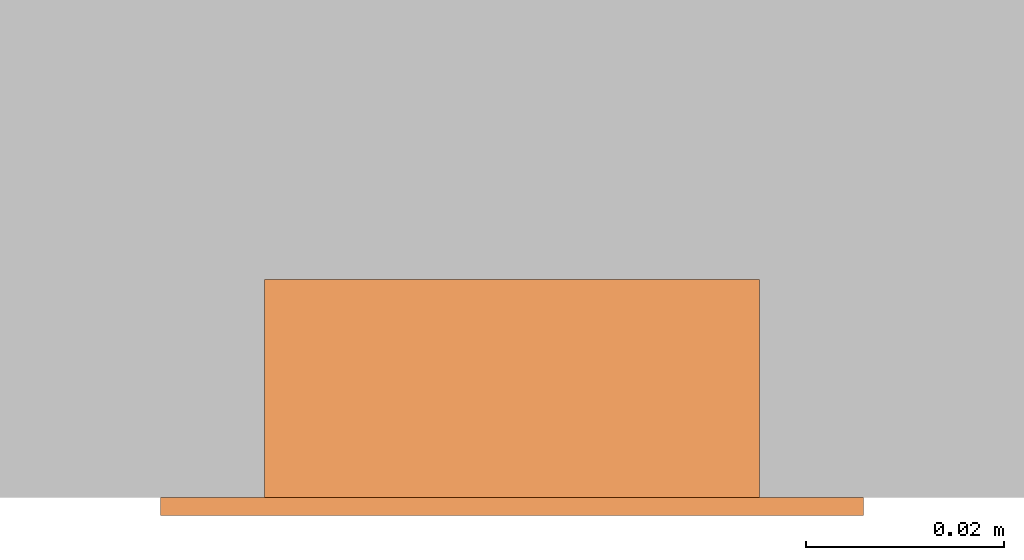
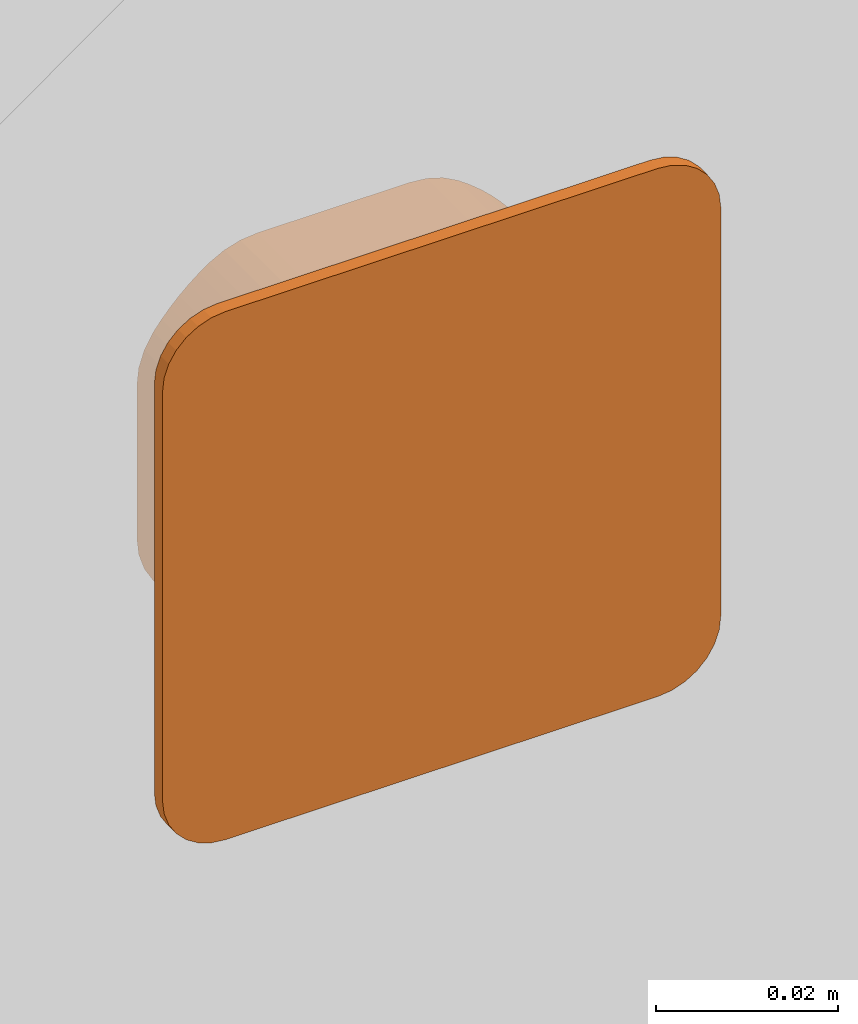
# One storey, part 2 of 2: 1 proxy.
"""IFC2X3 building model written with IfcOpenShell, lengths in metres."""

import ifcopenshell
import ifcopenshell.guid

model = None  # the IFC model being written
_history = None  # IfcOwnerHistory: only IFC2X3 demands one
_inside = {}  # id of a spatial element -> (the spatial element, [elements in it])
_under = {}  # id of a project, library or spatial element -> (it, [spatial elements below it])
_declared = {}  # id of a project -> (the project, [libraries it declares])
_typed = {}  # id of a type object -> (the type object, [elements of that type])
_made_of = {}  # id of a material, layer set ... -> (it, [elements and type objects made of it])


def new_model(schema):
    """Start an empty IFC model of exactly this schema.

    Asked for "IFC4X3", IfcOpenShell would pick the latest addendum, in which some entities
    have other attributes; the version numbers below select the first issue.
    IFC2X3 requires an IfcOwnerHistory on every rooted entity: one is made here for all.
    """
    global model, _history
    if schema == "IFC4X3":
        model = ifcopenshell.file(schema_version=(4, 3, 0, 0))
    else:
        model = ifcopenshell.file(schema=schema)
    _inside.clear()
    _under.clear()
    _declared.clear()
    _typed.clear()
    _made_of.clear()
    _history = None
    if model.schema == "IFC2X3":
        org = make("IfcOrganization", Name="unknown")
        user = make(
            "IfcPersonAndOrganization",
            ThePerson=make("IfcPerson", FamilyName="unknown"),
            TheOrganization=org,
        )
        app = make(
            "IfcApplication",
            ApplicationDeveloper=org,
            Version="unknown",
            ApplicationFullName="unknown",
            ApplicationIdentifier="unknown",
        )
        _history = make(
            "IfcOwnerHistory",
            OwningUser=user,
            OwningApplication=app,
            ChangeAction="ADDED",
            CreationDate=0,
        )
    return model


def make(cls, **values):
    """One entity of the class cls with the attributes given. An attribute that is None is left unset."""
    return model.create_entity(
        cls, **{name: value for name, value in values.items() if value is not None}
    )


def entity(cls, *values):
    """Any entity or typed value of the class cls, its attributes in the order of the schema. None: left unset."""
    e = model.create_entity(cls)
    for i, value in enumerate(values):
        if value is not None:
            e[i] = value
    return e


def rooted(cls, **values):
    """An entity with a GlobalId (a new one), such as an element, a storey or a relation."""
    return make(cls, GlobalId=ifcopenshell.guid.new(), OwnerHistory=_history, **values)


def si_unit(unit_type, name, prefix=None):
    """IfcSIUnit, for example si_unit("LENGTHUNIT", "METRE", prefix="MILLI")."""
    return make("IfcSIUnit", UnitType=unit_type, Prefix=prefix, Name=name)


def converted_unit(unit_type, name, factor, base, dimensions=None, offset=None):
    """IfcConversionBasedUnit, such as the inch: factor (a typed value) times the base unit."""
    return make(
        "IfcConversionBasedUnit"
        if offset is None
        else "IfcConversionBasedUnitWithOffset",
        ConversionOffset=offset,
        Dimensions=None
        if dimensions is None
        else entity("IfcDimensionalExponents", *dimensions),
        UnitType=unit_type,
        Name=name,
        ConversionFactor=make(
            "IfcMeasureWithUnit", ValueComponent=factor, UnitComponent=base
        ),
    )


def derived_unit(unit_type, elements):
    """IfcDerivedUnit: a product of units, each with its exponent."""
    return make(
        "IfcDerivedUnit",
        Elements=[
            make("IfcDerivedUnitElement", Unit=unit, Exponent=power)
            for unit, power in elements
        ],
        UnitType=unit_type,
    )


def assignment(units):
    """IfcUnitAssignment: the units of a project."""
    return None if units is None else make("IfcUnitAssignment", Units=units)


def point(xyz):
    """IfcCartesianPoint."""
    return None if xyz is None else make("IfcCartesianPoint", Coordinates=xyz)


def direction(xyz):
    """IfcDirection."""
    return None if xyz is None else make("IfcDirection", DirectionRatios=xyz)


def frame(location, z_axis=None, x_axis=None):
    """IfcAxis2Placement3D, a coordinate frame: its origin and axes. An axis left out is left unset."""
    return make(
        "IfcAxis2Placement3D",
        Location=point(location),
        Axis=direction(z_axis),
        RefDirection=direction(x_axis),
    )


def frame_2d(location, x_axis=None):
    """IfcAxis2Placement2D, a coordinate frame in the plane: its origin and x axis."""
    return make(
        "IfcAxis2Placement2D", Location=point(location), RefDirection=direction(x_axis)
    )


def origin():
    """The frame at (0, 0, 0) with its axes left unset."""
    return frame((0.0, 0.0, 0.0))


def place(relative_to, where):
    """IfcLocalPlacement: puts the frame where relative to a parent placement (None: the world)."""
    return make(
        "IfcLocalPlacement", PlacementRelTo=relative_to, RelativePlacement=where
    )


def context(
    kind, dimensions, precision=None, world=None, true_north=None, identifier=None
):
    """IfcGeometricRepresentationContext, for example the 3D "Model" context."""
    return make(
        "IfcGeometricRepresentationContext",
        ContextIdentifier=identifier,
        ContextType=kind,
        CoordinateSpaceDimension=dimensions,
        Precision=precision,
        WorldCoordinateSystem=world,
        TrueNorth=true_north,
    )


def subcontext(parent, identifier, kind, view, scale=None):
    """IfcGeometricRepresentationSubContext, for example "Body" below "Model"."""
    return make(
        "IfcGeometricRepresentationSubContext",
        ContextIdentifier=identifier,
        ContextType=kind,
        ParentContext=parent,
        TargetScale=scale,
        TargetView=view,
    )


def project(units=None, contexts=None):
    """IfcProject with its units and contexts."""
    return rooted(
        "IfcProject",
        Name="project",
        RepresentationContexts=contexts,
        UnitsInContext=assignment(units),
    )


def spatial(cls, under=None, at=None, **own):
    """A site, building, storey or space (cls), placed at a placement, below another one or the project."""
    s = rooted(cls, ObjectPlacement=at, **own)
    if under is not None:
        _under.setdefault(under.id(), (under, []))[1].append(s)
    return s


def polyline(points):
    """IfcPolyline through the points."""
    return make("IfcPolyline", Points=[point(p) for p in points])


def circle_curve(where, radius):
    """IfcCircle in the frame where."""
    return make("IfcCircle", Position=where, Radius=radius)


def parameter(value):
    """IfcParameterValue: where a trimmed curve begins or ends, as a parameter of its basis curve."""
    return model.create_entity("IfcParameterValue", value)


def trimmed(basis, trim1, trim2, sense, master):
    """IfcTrimmedCurve: the piece of a basis curve between two trims."""
    return make(
        "IfcTrimmedCurve",
        BasisCurve=basis,
        Trim1=trim1,
        Trim2=trim2,
        SenseAgreement=sense,
        MasterRepresentation=master,
    )


def segment(curve, same_sense, transition):
    """IfcCompositeCurveSegment."""
    return make(
        "IfcCompositeCurveSegment",
        Transition=transition,
        SameSense=same_sense,
        ParentCurve=curve,
    )


def composite_curve(segments, self_intersect=None):
    """IfcCompositeCurve: segments joined end to end."""
    return make("IfcCompositeCurve", Segments=segments, SelfIntersect=self_intersect)


def outline(outer, holes=None, kind="AREA"):
    """IfcArbitraryClosedProfileDef: a profile drawn as a closed curve; with holes, ...WithVoids."""
    if holes is None:
        return make("IfcArbitraryClosedProfileDef", ProfileType=kind, OuterCurve=outer)
    return make(
        "IfcArbitraryProfileDefWithVoids",
        ProfileType=kind,
        OuterCurve=outer,
        InnerCurves=holes,
    )


def extrude(swept, where, along, depth):
    """IfcExtrudedAreaSolid: the profile swept, set in the frame where, extruded along a direction by depth."""
    return make(
        "IfcExtrudedAreaSolid",
        SweptArea=swept,
        Position=where,
        ExtrudedDirection=direction(along),
        Depth=depth,
    )


def shape(context_of_items, identifier, shape_type, items):
    """IfcShapeRepresentation: the items that make up one representation, for example the "Body"."""
    return make(
        "IfcShapeRepresentation",
        ContextOfItems=context_of_items,
        RepresentationIdentifier=identifier,
        RepresentationType=shape_type,
        Items=items,
    )


def source(mapping_origin, context_of_items, identifier, shape_type, items):
    """IfcRepresentationMap: a shape defined once, which mapped items show again and again."""
    return make(
        "IfcRepresentationMap",
        MappingOrigin=mapping_origin,
        MappedRepresentation=shape(context_of_items, identifier, shape_type, items),
    )


def transform(
    local_origin,
    x_axis=None,
    y_axis=None,
    z_axis=None,
    scale=None,
    scale2=None,
    scale3=None,
    uniform=True,
):
    """IfcCartesianTransformationOperator3D, or its non-uniform kind. x_axis, y_axis, z_axis: its Axis1, 2, 3."""
    if uniform:
        return make(
            "IfcCartesianTransformationOperator3D",
            Axis1=direction(x_axis),
            Axis2=direction(y_axis),
            LocalOrigin=point(local_origin),
            Scale=scale,
            Axis3=direction(z_axis),
        )
    return make(
        "IfcCartesianTransformationOperator3DnonUniform",
        Axis1=direction(x_axis),
        Axis2=direction(y_axis),
        LocalOrigin=point(local_origin),
        Scale=scale,
        Axis3=direction(z_axis),
        Scale2=scale2,
        Scale3=scale3,
    )


def mapped(mapping_source, mapping_target):
    """IfcMappedItem: shows the shape of a source again, moved by a transform."""
    return make(
        "IfcMappedItem", MappingSource=mapping_source, MappingTarget=mapping_target
    )


def made_of(thing, what):
    """Note that an element or type object is made of a material, layer set ...; save() writes the relation."""
    if what is not None:
        _made_of.setdefault(what.id(), (what, []))[1].append(thing)
    return thing


def type_object(cls, material=None, **own):
    """A type object (cls), such as IfcWallType, which elements share."""
    return made_of(rooted(cls, **own), material)


def type_shapes(of_type, sources):
    """Give a type object the sources (RepresentationMaps) that its elements show as mapped items."""
    of_type.RepresentationMaps = sources


def element(
    cls,
    number,
    at=None,
    inside=None,
    cuts=None,
    type_object=None,
    material=None,
    context=None,
    identifier="Body",
    shape_type=None,
    held_by="IfcProductDefinitionShape",
    body=None,
    shapes=None,
    **own,
):
    """One element of the class cls, such as IfcWall. Its Tag is "e" and its number.

    at: its placement. inside: the storey or other place that contains it. cuts: it is an
    opening in that element (IfcRelVoidsElement). A single representation is given by context,
    identifier, shape_type and body (its items); several are given by shapes. held_by: the class
    of the entity that holds the representations. save() writes the other relations.
    """
    e = rooted(cls, Tag="e%d" % number, ObjectPlacement=at, **own)
    if body is not None:
        shapes = [shape(context, identifier, shape_type, body)]
    if shapes is not None:
        e.Representation = make(held_by, Representations=shapes)
    if inside is not None:
        _inside.setdefault(inside.id(), (inside, []))[1].append(e)
    if cuts is not None:
        rooted(
            "IfcRelVoidsElement", RelatingBuildingElement=cuts, RelatedOpeningElement=e
        )
    if type_object is not None:
        _typed.setdefault(type_object.id(), (type_object, []))[1].append(e)
    return made_of(e, material)


def aggregate(whole, parts):
    """IfcRelAggregates: a whole, such as a stair, and the parts it consists of."""
    return rooted("IfcRelAggregates", RelatingObject=whole, RelatedObjects=parts)


def save(model, path):
    """Write the relations noted so far, then the file.

    IfcRelAggregates (storeys below a building ...), IfcRelContainedInSpatialStructure (elements
    in a storey), IfcRelDefinesByType, IfcRelAssociatesMaterial and IfcRelDeclares: one each for
    every whole, place, type object, material and project.
    """
    for whole, parts in _under.values():
        aggregate(whole, parts)
    for where, things in _inside.values():
        rooted(
            "IfcRelContainedInSpatialStructure",
            RelatedElements=things,
            RelatingStructure=where,
        )
    for kind, things in _typed.values():
        rooted("IfcRelDefinesByType", RelatedObjects=things, RelatingType=kind)
    for what, things in _made_of.values():
        rooted("IfcRelAssociatesMaterial", RelatedObjects=things, RelatingMaterial=what)
    for by, libraries in _declared.values():
        rooted("IfcRelDeclares", RelatingContext=by, RelatedDefinitions=libraries)
    model.write(path)


model = new_model("IFC2X3")

# Units and contexts
model_context = context("Model", 3, precision=1e-05, world=origin(), true_north=direction((6.12303176911189e-17, 1.0)))
body_context = subcontext(model_context, "Body", "Model", "MODEL_VIEW")
ifc_project = project(units=[si_unit("LENGTHUNIT", "METRE"), si_unit("AREAUNIT", "SQUARE_METRE"), si_unit("VOLUMEUNIT", "CUBIC_METRE"), converted_unit("PLANEANGLEUNIT", "DEGREE", entity("IfcRatioMeasure", 0.0174532925199433), si_unit("PLANEANGLEUNIT", "RADIAN"), dimensions=[0, 0, 0, 0, 0, 0, 0]), si_unit("MASSUNIT", "GRAM", prefix="KILO"), si_unit("TIMEUNIT", "SECOND"), si_unit("FREQUENCYUNIT", "HERTZ"), si_unit("THERMODYNAMICTEMPERATUREUNIT", "DEGREE_CELSIUS"), derived_unit("THERMALTRANSMITTANCEUNIT", [(si_unit("MASSUNIT", "GRAM", prefix="KILO"), 1), (si_unit("THERMODYNAMICTEMPERATUREUNIT", "KELVIN"), -1), (si_unit("TIMEUNIT", "SECOND"), -3)]), derived_unit("VOLUMETRICFLOWRATEUNIT", [(si_unit("LENGTHUNIT", "METRE"), 3), (si_unit("TIMEUNIT", "SECOND"), -1)]), si_unit("ELECTRICCURRENTUNIT", "AMPERE"), si_unit("ELECTRICVOLTAGEUNIT", "VOLT"), si_unit("POWERUNIT", "WATT"), si_unit("FORCEUNIT", "NEWTON", prefix="KILO"), si_unit("ILLUMINANCEUNIT", "LUX"), si_unit("LUMINOUSFLUXUNIT", "LUMEN"), si_unit("LUMINOUSINTENSITYUNIT", "CANDELA"), derived_unit("USERDEFINED", [(si_unit("MASSUNIT", "GRAM", prefix="KILO"), -1), (si_unit("LENGTHUNIT", "METRE"), -2), (si_unit("TIMEUNIT", "SECOND"), 3), (si_unit("LUMINOUSFLUXUNIT", "LUMEN"), 1)]), derived_unit("LINEARVELOCITYUNIT", [(si_unit("LENGTHUNIT", "METRE"), 1), (si_unit("TIMEUNIT", "SECOND"), -1)]), si_unit("PRESSUREUNIT", "PASCAL"), derived_unit("USERDEFINED", [(si_unit("LENGTHUNIT", "METRE"), -2), (si_unit("MASSUNIT", "GRAM", prefix="KILO"), 1), (si_unit("TIMEUNIT", "SECOND"), -2)])], contexts=[model_context])

# Site, building, storey
site_placement = place(None, origin())
site = spatial("IfcSite", under=ifc_project, at=site_placement, CompositionType="ELEMENT")
building_placement = place(site_placement, origin())
building = spatial("IfcBuilding", under=site, at=building_placement, CompositionType="ELEMENT")
storey_placement = place(building_placement, origin())
storey = spatial("IfcBuildingStorey", under=building, at=storey_placement, Name="Ebene 0", CompositionType="ELEMENT", Elevation=0.0)

# Proxy
building_element_proxy_type = type_object("IfcBuildingElementProxyType", Name="KNX", PredefinedType="NOTDEFINED")
shared_shape = source(origin(), body_context, "Body", "SweptSolid", [
    extrude(outline(composite_curve([segment(trimmed(circle_curve(frame_2d((-0.00971255040319162, 0.00854377441429179), x_axis=(1.0, 0.0)), 0.0110000000000002), [parameter(90.0000000000001)], [parameter(123.904222233697)], True, "PARAMETER"), True, "CONTINUOUS"), segment(trimmed(circle_curve(frame_2d((-3.46115730478118e-05, -0.00585622558570819), x_axis=(1.0, 0.0)), 0.0283499999999995), [parameter(123.904222233697)], [parameter(133.853542096747)], True, "PARAMETER"), True, "CONTINUOUS"), segment(trimmed(circle_curve(frame_2d((-3.46115730478118e-05, -0.00585622558570846), x_axis=(1.0, 0.0)), 0.0283500000000006), [parameter(133.853542096747)], [parameter(143.79574278755)], True, "PARAMETER"), True, "CONTINUOUS"), segment(trimmed(circle_curve(frame_2d((-0.0140346115730479, 0.00439182300902431), x_axis=(1.0, 0.0)), 0.0109999999999997), [parameter(143.79574278755)], [parameter(180.0)], True, "PARAMETER"), True, "CONTINUOUS"), segment(polyline([(-0.0250346115730475, 0.00439182300902431), (-0.0250346115730481, -0.0161042741804407)]), True, "CONTINUOUS"), segment(trimmed(circle_curve(frame_2d((-0.0140346115730479, -0.0161042741804407), x_axis=(1.0, 0.0)), 0.0109999999999997), [parameter(180.0)], [parameter(216.204257212449)], True, "PARAMETER"), True, "CONTINUOUS"), segment(trimmed(circle_curve(frame_2d((-3.46115730478118e-05, -0.00585622558570819), x_axis=(1.0, 0.0)), 0.0283499999999995), [parameter(216.204257212449)], [parameter(231.705184729721)], True, "PARAMETER"), True, "CONTINUOUS"), segment(polyline([(-0.0176033337804244, -0.0281062255857083), (0.0175341106343034, -0.0281062255857083)]), True, "CONTINUOUS"), segment(trimmed(circle_curve(frame_2d((-3.46115730731846e-05, -0.00585622558570819), x_axis=(-1.0, 0.0)), 0.0283499999999995), [parameter(128.294815270279)], [parameter(143.79574278755)], True, "PARAMETER"), True, "CONTINUOUS"), segment(trimmed(circle_curve(frame_2d((0.0139653884269269, -0.0161042741804407), x_axis=(-1.0, 0.0)), 0.0109999999999997), [parameter(143.79574278755)], [parameter(179.999999999999)], True, "PARAMETER"), True, "CONTINUOUS"), segment(polyline([(0.0249653884269265, -0.0161042741804408), (0.0249653884269271, 0.00439182300902431)]), True, "CONTINUOUS"), segment(trimmed(circle_curve(frame_2d((0.0139653884269269, 0.00439182300902431), x_axis=(-1.0, 0.0)), 0.0109999999999997), [parameter(180.0)], [parameter(216.20425721245)], True, "PARAMETER"), True, "CONTINUOUS"), segment(trimmed(circle_curve(frame_2d((-3.46115730731846e-05, -0.00585622558570846), x_axis=(-1.0, 0.0)), 0.0283500000000006), [parameter(216.20425721245)], [parameter(224.573459957787)], True, "PARAMETER"), True, "CONTINUOUS"), segment(trimmed(circle_curve(frame_2d((-3.46115730731846e-05, -0.00585622558570819), x_axis=(-1.0, 0.0)), 0.0283499999999995), [parameter(224.573459957787)], [parameter(236.095777766303)], True, "PARAMETER"), True, "CONTINUOUS"), segment(trimmed(circle_curve(frame_2d((0.00964332725707062, 0.00854377441429179), x_axis=(-1.0, 0.0)), 0.0110000000000002), [parameter(236.095777766303)], [parameter(270.0)], True, "PARAMETER"), True, "CONTINUOUS"), segment(polyline([(0.00964332725707069, 0.019543774414292), (-0.00971255040319162, 0.019543774414292)]), True, "CONTINUOUS")], self_intersect=False)), frame((3.4611573066762e-05, 0.00585622558568301, -0.0220000000000019)), (0.0, 0.0, 1.0), 0.022),
    extrude(outline(composite_curve([segment(trimmed(circle_curve(frame_2d((-0.0274749999999998, 0.027475), x_axis=(1.0, 0.0)), 0.00800000000000035), [parameter(90.0000000000001)], [parameter(180.0)], True, "PARAMETER"), True, "CONTINUOUS"), segment(polyline([(-0.0354750000000002, 0.027475), (-0.0354749999999996, -0.027475)]), True, "CONTINUOUS"), segment(trimmed(circle_curve(frame_2d((-0.0274749999999998, -0.027475), x_axis=(1.0, 0.0)), 0.00800000000000035), [parameter(180.0)], [parameter(270.0)], True, "PARAMETER"), True, "CONTINUOUS"), segment(polyline([(-0.0274749999999998, -0.0354750000000003), (0.0274750000000001, -0.0354749999999998)]), True, "CONTINUOUS"), segment(trimmed(circle_curve(frame_2d((0.0274750000000001, -0.027475), x_axis=(1.0, 0.0)), 0.00799999999999981), [parameter(270.0)], [parameter(0.0)], True, "PARAMETER"), True, "CONTINUOUS"), segment(polyline([(0.0354749999999999, -0.027475), (0.0354750000000005, 0.027475)]), True, "CONTINUOUS"), segment(trimmed(circle_curve(frame_2d((0.0274750000000001, 0.027475), x_axis=(1.0, 0.0)), 0.00799999999999981), [parameter(0.0)], [parameter(90.0000000000001)], True, "PARAMETER"), True, "CONTINUOUS"), segment(polyline([(0.0274750000000001, 0.0354749999999998), (-0.0274749999999998, 0.0354749999999998)]), True, "CONTINUOUS")], self_intersect=False)), origin(), (0.0, 0.0, 1.0), 0.0018),
])
type_shapes(building_element_proxy_type, [shared_shape])
proxy_placement = place(storey_placement, frame((-7.5192018927039, -2.38240134987377, 1.36733775807096), z_axis=(0.0, -1.0, 0.0), x_axis=(1.0, 0.0, 0.0)))
element("IfcBuildingElementProxy", 1, at=proxy_placement, inside=storey, type_object=building_element_proxy_type, Name="057000", ObjectType="KNX", context=body_context, shape_type="MappedRepresentation", body=[
    mapped(shared_shape, transform((0.0, 0.0, 0.0), scale=1.0)),
])

save(model, "model.ifc")
